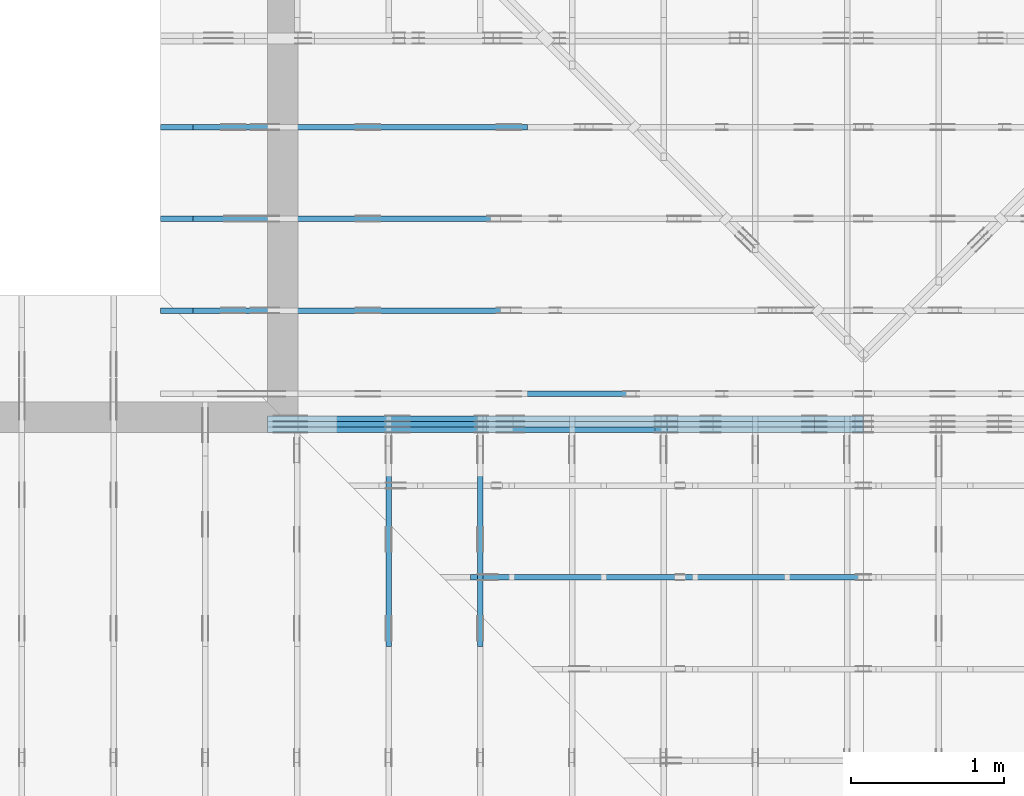
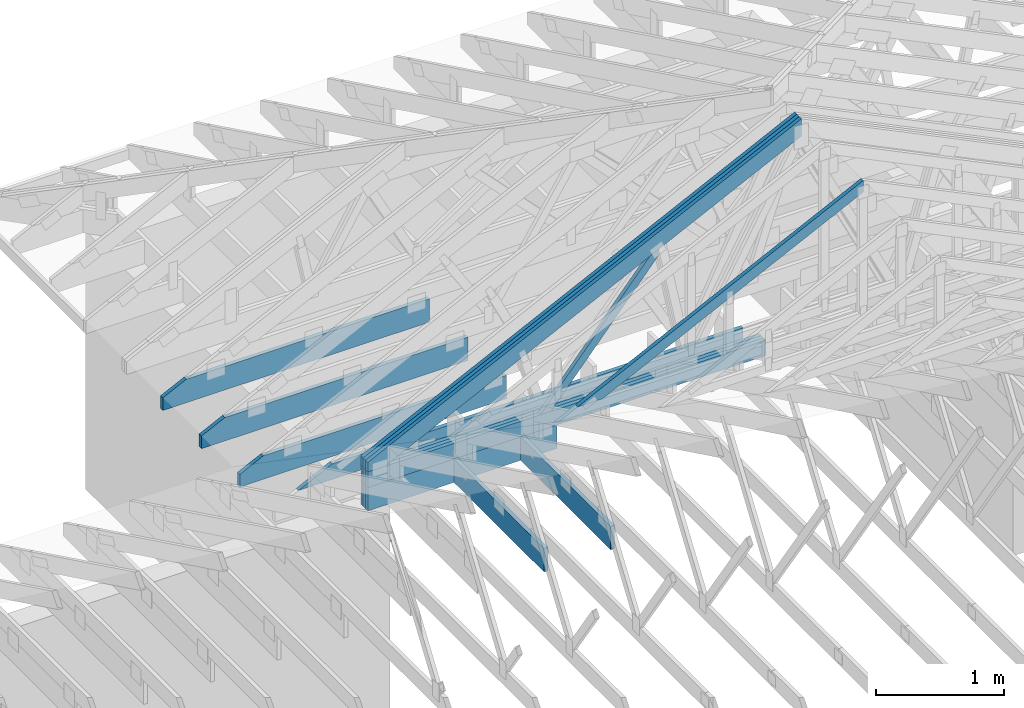
# One storey, part 22 of 159: 17 members, 8 elements without a shape of their own.
"""IFC2X3 building model written with IfcOpenShell, lengths in millimetres."""

from ifc_helpers import new_model, si_unit, frame, origin, origin_with_axes, origin_2d, place, context, project, spatial, faceted_brep, element, aggregate, save


model = new_model("IFC2X3")

# Units and contexts
model_context = context("Model", 3, precision=1e-05, world=origin())
plan_context = context("Plan", 2, precision=1e-05, world=origin_2d())
ifc_project = project(units=[si_unit("LENGTHUNIT", "METRE", prefix="MILLI"), si_unit("AREAUNIT", "SQUARE_METRE"), si_unit("VOLUMEUNIT", "CUBIC_METRE"), si_unit("SOLIDANGLEUNIT", "STERADIAN"), si_unit("PLANEANGLEUNIT", "RADIAN"), si_unit("MASSUNIT", "GRAM"), si_unit("TIMEUNIT", "SECOND"), si_unit("THERMODYNAMICTEMPERATUREUNIT", "DEGREE_CELSIUS"), si_unit("LUMINOUSINTENSITYUNIT", "LUMEN")], contexts=[model_context, plan_context])

# Site, building, storey
site_placement = place(None, origin_with_axes())
site = spatial("IfcSite", under=ifc_project, at=site_placement, CompositionType="ELEMENT")
building_placement = place(site_placement, origin_with_axes())
building = spatial("IfcBuilding", under=site, at=building_placement, Name="Plan 1", CompositionType="ELEMENT")
storey_placement = place(building_placement, origin_with_axes())
storey = spatial("IfcBuildingStorey", under=building, at=storey_placement, Name="Etasje 1", CompositionType="ELEMENT", Elevation=0.0)

# Assembly, members
assembly_1_placement = place(storey_placement, frame((10700.012663101485, 8801.999999990367, 0.0), z_axis=(0.0, -1.0, 6.123031769111886e-17), x_axis=(1.0, 0.0, 0.0)))
assembly_1 = element("IfcElementAssembly", 1, at=assembly_1_placement, inside=storey, Name="T8 (1)", AssemblyPlace="FACTORY", PredefinedType="TRUSS")
member_1_placement = place(assembly_1_placement, frame((29.255809478811415, 311.016701437081, -36.0), z_axis=(0.0, 0.0, 1.0), x_axis=(0.898794046299167, 0.4383711467890774, 0.0)))
member_1 = element("IfcMember", 2, at=member_1_placement, Name="T8-O16", context=model_context, shape_type="Brep", body=[
    faceted_brep([(4378.781899466834, 147.99995674299475, 36.0), (39.634367764929806, 147.99995674299475, 36.0), (0.0, 66.73753437720632, 36.0), (136.8321636846506, 2.8984224002215342e-05, 36.0), (4306.597497456938, 2.8984224002215342e-05, 36.0), (39.634367764929806, 147.99995674299475, 4.853649859466585e-15), (4378.781899466834, 147.99995674299475, 5.362284136089503e-13), (4306.597497456938, 2.8984224002215342e-05, 5.273886658741316e-13), (136.8321636846506, 2.8984224002215342e-05, 1.6756553705548666e-14), (0.0, 66.73753437720632, 0.0), (-1.0658141036401503e-14, 66.73753437720632, 6.040230958362988e-31), (-7.105427357601002e-15, 66.73753437720632, 36.0), (39.634368079159835, 148.00003150847562, 36.0), (39.634368079159835, 148.00003150847562, 7.19847561279507e-31), (136.8321585099013, 3.1508118006229324e-05, 3.565331076937772e-30), (136.8321585099013, 3.1508118006229324e-05, 36.0), (1.0658141036401503e-14, 66.73753437720634, 36.0), (1.0658141036401503e-14, 66.73753437720634, -1.4875703872059745e-30), (4306.5975128248465, 3.150888393548654e-05, -1.4774859213225477e-29), (4306.5975128248465, 3.150888393769083e-05, 36.0), (136.83215850990132, 3.15081180800492e-05, 36.0), (136.83215850990132, 3.150811807784491e-05, -4.694367723059667e-31), (4378.781935933059, 148.0000315098364, 4.4162180043231723e-29), (4378.781935933059, 148.0000315098364, 36.0), (4306.5975128248465, 3.150888392156048e-05, 36.0), (4306.5975128248465, 3.150888392156048e-05, 4.466959351877897e-29), (39.634368079159856, 148.00003150847562, 0.0), (39.634368079159856, 148.00003150847562, 36.0), (4378.781935933059, 148.0000315098358, 36.0), (4378.781935933059, 148.0000315098358, -2.208810534618833e-29)], [[[0, 1, 2, 3, 4]], [[5, 6, 7, 8, 9]], [[10, 11, 12, 13]], [[14, 15, 16, 17]], [[18, 19, 20, 21]], [[22, 23, 24, 25]], [[26, 27, 28, 29]]]),
])
member_2_placement = place(assembly_1_placement, frame((29.255809478811415, 311.016701437081, -72.0), z_axis=(0.0, 0.0, 1.0), x_axis=(0.898794046299167, 0.4383711467890774, 0.0)))
member_2 = element("IfcMember", 3, at=member_2_placement, Name="T8-O16", context=model_context, shape_type="Brep", body=[
    faceted_brep([(4378.781899466834, 147.99995674299475, 36.0), (39.634367764929806, 147.99995674299475, 36.0), (0.0, 66.73753437720632, 36.0), (136.8321636846506, 2.8984224002215342e-05, 36.0), (4306.597497456938, 2.8984224002215342e-05, 36.0), (39.634367764929806, 147.99995674299475, 4.853649859466585e-15), (4378.781899466834, 147.99995674299475, 5.362284136089503e-13), (4306.597497456938, 2.8984224002215342e-05, 5.273886658741316e-13), (136.8321636846506, 2.8984224002215342e-05, 1.6756553705548666e-14), (0.0, 66.73753437720632, 0.0), (-1.0658141036401503e-14, 66.73753437720632, 6.040230958362988e-31), (-7.105427357601002e-15, 66.73753437720632, 36.0), (39.634368079159835, 148.00003150847562, 36.0), (39.634368079159835, 148.00003150847562, 7.19847561279507e-31), (136.8321585099013, 3.1508118006229324e-05, 3.565331076937772e-30), (136.8321585099013, 3.1508118006229324e-05, 36.0), (1.0658141036401503e-14, 66.73753437720634, 36.0), (1.0658141036401503e-14, 66.73753437720634, -1.4875703872059745e-30), (4306.5975128248465, 3.150888393548654e-05, -1.4774859213225477e-29), (4306.5975128248465, 3.150888393769083e-05, 36.0), (136.83215850990132, 3.15081180800492e-05, 36.0), (136.83215850990132, 3.150811807784491e-05, -4.694367723059667e-31), (4378.781935933059, 148.0000315098364, 4.4162180043231723e-29), (4378.781935933059, 148.0000315098364, 36.0), (4306.5975128248465, 3.150888392156048e-05, 36.0), (4306.5975128248465, 3.150888392156048e-05, 4.466959351877897e-29), (39.634368079159856, 148.00003150847562, 0.0), (39.634368079159856, 148.00003150847562, 36.0), (4378.781935933059, 148.0000315098358, 36.0), (4378.781935933059, 148.0000315098358, -2.208810534618833e-29)], [[[0, 1, 2, 3, 4]], [[5, 6, 7, 8, 9]], [[10, 11, 12, 13]], [[14, 15, 16, 17]], [[18, 19, 20, 21]], [[22, 23, 24, 25]], [[26, 27, 28, 29]]]),
])
member_3_placement = place(assembly_1_placement, frame((29.255809478811415, 311.016701437081, -108.0), z_axis=(0.0, 0.0, 1.0), x_axis=(0.898794046299167, 0.4383711467890774, 0.0)))
member_3 = element("IfcMember", 4, at=member_3_placement, Name="T8-O16", context=model_context, shape_type="Brep", body=[
    faceted_brep([(4378.781899466834, 147.99995674299475, 36.0), (39.634367764929806, 147.99995674299475, 36.0), (0.0, 66.73753437720632, 36.0), (136.8321636846506, 2.8984224002215342e-05, 36.0), (4306.597497456938, 2.8984224002215342e-05, 36.0), (39.634367764929806, 147.99995674299475, 4.853649859466585e-15), (4378.781899466834, 147.99995674299475, 5.362284136089503e-13), (4306.597497456938, 2.8984224002215342e-05, 5.273886658741316e-13), (136.8321636846506, 2.8984224002215342e-05, 1.6756553705548666e-14), (0.0, 66.73753437720632, 0.0), (-1.0658141036401503e-14, 66.73753437720632, 6.040230958362988e-31), (-7.105427357601002e-15, 66.73753437720632, 36.0), (39.634368079159835, 148.00003150847562, 36.0), (39.634368079159835, 148.00003150847562, 7.19847561279507e-31), (136.8321585099013, 3.1508118006229324e-05, 3.565331076937772e-30), (136.8321585099013, 3.1508118006229324e-05, 36.0), (1.0658141036401503e-14, 66.73753437720634, 36.0), (1.0658141036401503e-14, 66.73753437720634, -1.4875703872059745e-30), (4306.5975128248465, 3.150888393548654e-05, -1.4774859213225477e-29), (4306.5975128248465, 3.150888393769083e-05, 36.0), (136.83215850990132, 3.15081180800492e-05, 36.0), (136.83215850990132, 3.150811807784491e-05, -4.694367723059667e-31), (4378.781935933059, 148.0000315098364, 4.4162180043231723e-29), (4378.781935933059, 148.0000315098364, 36.0), (4306.5975128248465, 3.150888392156048e-05, 36.0), (4306.5975128248465, 3.150888392156048e-05, 4.466959351877897e-29), (39.634368079159856, 148.00003150847562, 0.0), (39.634368079159856, 148.00003150847562, 36.0), (4378.781935933059, 148.0000315098358, 36.0), (4378.781935933059, 148.0000315098358, -2.208810534618833e-29)], [[[0, 1, 2, 3, 4]], [[5, 6, 7, 8, 9]], [[10, 11, 12, 13]], [[14, 15, 16, 17]], [[18, 19, 20, 21]], [[22, 23, 24, 25]], [[26, 27, 28, 29]]]),
])
member_4_placement = place(assembly_1_placement, frame((3580.0000000000005, 371.0, -36.0), z_axis=(0.0, 0.0, 1.0), x_axis=(-1.0, 1.2246063538223773e-16, 0.0)))
member_4 = element("IfcMember", 5, at=member_4_placement, Name="T8-U40", context=model_context, shape_type="Brep", body=[
    faceted_brep([(3580.0000000000005, 148.00000000000045, 36.0), (4.547473508864641e-13, 148.00000000000045, 36.0), (4.547473508864641e-13, 0.0, 36.0), (3580.0000000000005, 0.0, 36.0), (4.547473508864641e-13, 148.00000000000045, 5.56886495279458e-29), (3580.0000000000005, 148.00000000000045, 4.384090746684111e-13), (3580.0000000000005, 0.0, 4.384090746684111e-13), (4.547473508864641e-13, 0.0, 5.56886495279458e-29), (4.176648714595935e-29, 3.410605131648481e-13, -2.5573752767891235e-45), (2.204291436880321e-15, 3.410605131648481e-13, 36.0), (2.0328465473451507e-14, 148.00000000000037, 36.0), (1.8124174036571228e-14, 148.00000000000037, -1.1097489341483845e-30), (3580.0000000000005, -3.165530988377686e-13, 4.7226971571917616e-29), (3580.0000000000005, -3.143488074008883e-13, 36.0), (4.049083948919771e-31, 3.4326480460172837e-13, 36.0), (0.0, 3.410605131648481e-13, 0.0), (3580.0000000000005, 148.00000000000045, 0.0), (3580.0000000000005, 148.00000000000045, 36.0), (3580.0000000000005, 4.547473508864641e-13, 36.0), (3580.0000000000005, 4.547473508864641e-13, 0.0), (0.0, 148.00000000000037, 0.0), (0.0, 148.00000000000037, 36.0), (3580.0000000000005, 148.00000000000014, 36.0), (3580.0000000000005, 148.00000000000014, -2.0510383535746307e-29)], [[[0, 1, 2, 3]], [[4, 5, 6, 7]], [[8, 9, 10, 11]], [[12, 13, 14, 15]], [[16, 17, 18, 19]], [[20, 21, 22, 23]]]),
])
member_5_placement = place(assembly_1_placement, frame((3580.0000000000005, 371.0, -72.0), z_axis=(0.0, 0.0, 1.0), x_axis=(-1.0, 1.2246063538223773e-16, 0.0)))
member_5 = element("IfcMember", 6, at=member_5_placement, Name="T8-U40", context=model_context, shape_type="Brep", body=[
    faceted_brep([(3580.0000000000005, 148.00000000000045, 36.0), (4.547473508864641e-13, 148.00000000000045, 36.0), (4.547473508864641e-13, 0.0, 36.0), (3580.0000000000005, 0.0, 36.0), (4.547473508864641e-13, 148.00000000000045, 5.56886495279458e-29), (3580.0000000000005, 148.00000000000045, 4.384090746684111e-13), (3580.0000000000005, 0.0, 4.384090746684111e-13), (4.547473508864641e-13, 0.0, 5.56886495279458e-29), (4.176648714595935e-29, 3.410605131648481e-13, -2.5573752767891235e-45), (2.204291436880321e-15, 3.410605131648481e-13, 36.0), (2.0328465473451507e-14, 148.00000000000037, 36.0), (1.8124174036571228e-14, 148.00000000000037, -1.1097489341483845e-30), (3580.0000000000005, -3.165530988377686e-13, 4.7226971571917616e-29), (3580.0000000000005, -3.143488074008883e-13, 36.0), (4.049083948919771e-31, 3.4326480460172837e-13, 36.0), (0.0, 3.410605131648481e-13, 0.0), (3580.0000000000005, 148.00000000000045, 0.0), (3580.0000000000005, 148.00000000000045, 36.0), (3580.0000000000005, 4.547473508864641e-13, 36.0), (3580.0000000000005, 4.547473508864641e-13, 0.0), (0.0, 148.00000000000037, 0.0), (0.0, 148.00000000000037, 36.0), (3580.0000000000005, 148.00000000000014, 36.0), (3580.0000000000005, 148.00000000000014, -2.0510383535746307e-29)], [[[0, 1, 2, 3]], [[4, 5, 6, 7]], [[8, 9, 10, 11]], [[12, 13, 14, 15]], [[16, 17, 18, 19]], [[20, 21, 22, 23]]]),
])
member_6_placement = place(assembly_1_placement, frame((3580.0000000000005, 371.0, -108.0), z_axis=(0.0, 0.0, 1.0), x_axis=(-1.0, 1.2246063538223773e-16, 0.0)))
member_6 = element("IfcMember", 7, at=member_6_placement, Name="T8-U40", context=model_context, shape_type="Brep", body=[
    faceted_brep([(3580.0000000000005, 148.00000000000045, 36.0), (4.547473508864641e-13, 148.00000000000045, 36.0), (4.547473508864641e-13, 0.0, 36.0), (3580.0000000000005, 0.0, 36.0), (4.547473508864641e-13, 148.00000000000045, 5.56886495279458e-29), (3580.0000000000005, 148.00000000000045, 4.384090746684111e-13), (3580.0000000000005, 0.0, 4.384090746684111e-13), (4.547473508864641e-13, 0.0, 5.56886495279458e-29), (4.176648714595935e-29, 3.410605131648481e-13, -2.5573752767891235e-45), (2.204291436880321e-15, 3.410605131648481e-13, 36.0), (2.0328465473451507e-14, 148.00000000000037, 36.0), (1.8124174036571228e-14, 148.00000000000037, -1.1097489341483845e-30), (3580.0000000000005, -3.165530988377686e-13, 4.7226971571917616e-29), (3580.0000000000005, -3.143488074008883e-13, 36.0), (4.049083948919771e-31, 3.4326480460172837e-13, 36.0), (0.0, 3.410605131648481e-13, 0.0), (3580.0000000000005, 148.00000000000045, 0.0), (3580.0000000000005, 148.00000000000045, 36.0), (3580.0000000000005, 4.547473508864641e-13, 36.0), (3580.0000000000005, 4.547473508864641e-13, 0.0), (0.0, 148.00000000000037, 0.0), (0.0, 148.00000000000037, 36.0), (3580.0000000000005, 148.00000000000014, 36.0), (3580.0000000000005, 148.00000000000014, -2.0510383535746307e-29)], [[[0, 1, 2, 3]], [[4, 5, 6, 7]], [[8, 9, 10, 11]], [[12, 13, 14, 15]], [[16, 17, 18, 19]], [[20, 21, 22, 23]]]),
])
member_7_placement = place(assembly_1_placement, frame((-2.0928459567573152e-14, 0.0, -36.0), z_axis=(0.0, 0.0, 1.0), x_axis=(1.0, 0.0, 0.0)))
member_7 = element("IfcMember", 8, at=member_7_placement, Name="T8-KI2", context=model_context, shape_type="Brep", body=[
    faceted_brep([(1700.0, 223.0, 36.0), (1.3638103741762855e-14, 223.0, 36.0), (0.0, 0.0, 36.0), (1700.0, 0.0, 36.0), (1.3638103741762855e-14, 223.0, 1.670130849625153e-30), (1700.0, 223.0, 2.0818308014980413e-13), (1700.0, 0.0, 2.0818308014980413e-13), (0.0, 0.0, 0.0), (6.760513219066083e-22, 0.0, 0.0), (2.204292112931601e-15, -2.6993892992798474e-31, 36.0), (2.9513013803170614e-14, 223.0, 36.0), (2.7308722366290335e-14, 223.0, -8.370563038680858e-31), (1700.0, -3.122746202247062e-13, 1.9120674203232252e-29), (1700.0, -3.100703287878259e-13, 36.0), (6.760513223115168e-22, 2.204291436880279e-15, 36.0), (6.760513219066083e-22, -1.2418451164752748e-37, 7.603857100494559e-54), (1700.0, 223.0, 0.0), (1700.0, 223.0, 36.0), (1700.0, 0.0, 36.0), (1700.0, 0.0, 0.0), (1.3638104028317929e-14, 223.0, 0.0), (1.3638104028317929e-14, 223.0, 36.0), (1700.0, 222.9999999999999, 36.0), (1700.0, 222.9999999999999, -6.310887241768095e-30)], [[[0, 1, 2, 3]], [[4, 5, 6, 7]], [[8, 9, 10, 11]], [[12, 13, 14, 15]], [[16, 17, 18, 19]], [[20, 21, 22, 23]]]),
])
member_8_placement = place(assembly_1_placement, frame((-2.0928459567573152e-14, 0.0, -72.0), z_axis=(0.0, 0.0, 1.0), x_axis=(1.0, 0.0, 0.0)))
member_8 = element("IfcMember", 9, at=member_8_placement, Name="T8-KI2", context=model_context, shape_type="Brep", body=[
    faceted_brep([(1700.0, 223.0, 36.0), (1.3638103741762855e-14, 223.0, 36.0), (0.0, 0.0, 36.0), (1700.0, 0.0, 36.0), (1.3638103741762855e-14, 223.0, 1.670130849625153e-30), (1700.0, 223.0, 2.0818308014980413e-13), (1700.0, 0.0, 2.0818308014980413e-13), (0.0, 0.0, 0.0), (6.760513219066083e-22, 0.0, 0.0), (2.204292112931601e-15, -2.6993892992798474e-31, 36.0), (2.9513013803170614e-14, 223.0, 36.0), (2.7308722366290335e-14, 223.0, -8.370563038680858e-31), (1700.0, -3.122746202247062e-13, 1.9120674203232252e-29), (1700.0, -3.100703287878259e-13, 36.0), (6.760513223115168e-22, 2.204291436880279e-15, 36.0), (6.760513219066083e-22, -1.2418451164752748e-37, 7.603857100494559e-54), (1700.0, 223.0, 0.0), (1700.0, 223.0, 36.0), (1700.0, 0.0, 36.0), (1700.0, 0.0, 0.0), (1.3638104028317929e-14, 223.0, 0.0), (1.3638104028317929e-14, 223.0, 36.0), (1700.0, 222.9999999999999, 36.0), (1700.0, 222.9999999999999, -6.310887241768095e-30)], [[[0, 1, 2, 3]], [[4, 5, 6, 7]], [[8, 9, 10, 11]], [[12, 13, 14, 15]], [[16, 17, 18, 19]], [[20, 21, 22, 23]]]),
])
member_9_placement = place(assembly_1_placement, frame((-2.0928459567573152e-14, 0.0, -108.0), z_axis=(0.0, 0.0, 1.0), x_axis=(1.0, 0.0, 0.0)))
member_9 = element("IfcMember", 10, at=member_9_placement, Name="T8-KI2", context=model_context, shape_type="Brep", body=[
    faceted_brep([(1700.0, 223.0, 36.0), (1.3638103741762855e-14, 223.0, 36.0), (0.0, 0.0, 36.0), (1700.0, 0.0, 36.0), (1.3638103741762855e-14, 223.0, 1.670130849625153e-30), (1700.0, 223.0, 2.0818308014980413e-13), (1700.0, 0.0, 2.0818308014980413e-13), (0.0, 0.0, 0.0), (6.760513219066083e-22, 0.0, 0.0), (2.204292112931601e-15, -2.6993892992798474e-31, 36.0), (2.9513013803170614e-14, 223.0, 36.0), (2.7308722366290335e-14, 223.0, -8.370563038680858e-31), (1700.0, -3.122746202247062e-13, 1.9120674203232252e-29), (1700.0, -3.100703287878259e-13, 36.0), (6.760513223115168e-22, 2.204291436880279e-15, 36.0), (6.760513219066083e-22, -1.2418451164752748e-37, 7.603857100494559e-54), (1700.0, 223.0, 0.0), (1700.0, 223.0, 36.0), (1700.0, 0.0, 36.0), (1700.0, 0.0, 0.0), (1.3638104028317929e-14, 223.0, 0.0), (1.3638104028317929e-14, 223.0, 36.0), (1700.0, 222.9999999999999, 36.0), (1700.0, 222.9999999999999, -6.310887241768095e-30)], [[[0, 1, 2, 3]], [[4, 5, 6, 7]], [[8, 9, 10, 11]], [[12, 13, 14, 15]], [[16, 17, 18, 19]], [[20, 21, 22, 23]]]),
])
member_10_placement = place(assembly_1_placement, frame((2588.98150183582, 1596.6429683989554, -36.0), z_axis=(0.0, 0.0, 1.0), x_axis=(-0.6458357364032298, -0.7634763922902252, 0.0)))
member_10 = element("IfcMember", 11, at=member_10_placement, Name="T8-D24", context=model_context, shape_type="Brep", body=[
    faceted_brep([(1543.5932006244534, 72.99998709430429, 36.0), (28.88351769405017, 72.99998709430429, 36.0), (1.4494809875031933e-05, 36.500010319543776, 36.0), (82.86761682691758, 1.7008971553877927e-05, 36.0), (1605.3449359283989, 1.7008971553877927e-05, 36.0), (28.88351769405017, 72.99998709430429, 3.5370939288874897e-15), (1543.5932006244534, 72.99998709430429, 1.890294041201725e-13), (1605.3449359283989, 1.7008971553877927e-05, 1.9659156086144943e-13), (82.86761682691758, 1.7008971553877927e-05, 1.0148021009236142e-14), (1.4494809875031933e-05, 36.500010319543776, 1.7750436270411443e-21), (-3.552713678800501e-15, 36.499999999876884, 3.944304526105059e-31), (-3.552713678800501e-15, 36.499999999876884, 36.0), (28.883460935114723, 73.00000000000034, 36.0), (28.883460935114723, 73.00000000000034, 3.944304526105059e-31), (82.8676636786472, -3.552713678800501e-15, 0.0), (82.8676636786472, 0.0, 36.0), (1.7763568394002505e-15, 36.49999999987688, 36.0), (0.0, 36.49999999987688, 0.0), (1605.3449468455124, -3.4439067704007967e-13, 7.67758000929694e-29), (1605.3449468455124, -3.421863856031994e-13, 36.0), (82.8676636786472, -6.252108242574337e-14, 36.0), (82.8676636786472, -6.472537386262365e-14, 3.963155204284888e-30), (1543.5931897073374, 73.00000000000114, 1.262177448353619e-29), (1543.5931897073374, 73.00000000000114, 36.0), (1605.3449468455124, 9.094947017729282e-13, 36.0), (1605.3449468455124, 9.094947017729282e-13, 0.0), (28.883460935114726, 73.00000000000036, 7.888609052210118e-31), (28.883460935114726, 73.00000000000036, 36.0), (1543.5931897073374, 73.0000000000016, 36.0), (1543.5931897073374, 73.0000000000016, 2.8398992587956425e-29)], [[[0, 1, 2, 3, 4]], [[5, 6, 7, 8, 9]], [[10, 11, 12, 13]], [[14, 15, 16, 17]], [[18, 19, 20, 21]], [[22, 23, 24, 25]], [[26, 27, 28, 29]]]),
])
aggregate(assembly_1, [member_1, member_2, member_3, member_4, member_5, member_6, member_7, member_8, member_9, member_10])

# Assembly, member
assembly_2_placement = place(storey_placement, frame((19200.01266310149, 9617.999978540158, 1.1021457184401395e-15), z_axis=(1.2246063538223773e-16, 1.0, 6.123031769111886e-17), x_axis=(-1.0, 1.2246063538223773e-16, 0.0)))
assembly_2 = element("IfcElementAssembly", 12, at=assembly_2_placement, inside=storey, Name="V12 (104)", AssemblyPlace="FACTORY", PredefinedType="TRUSS")
member_11_placement = place(assembly_2_placement, frame((6799.999999999984, 0.0, -36.0), z_axis=(0.0, 0.0, 1.0), x_axis=(1.0, 0.0, 0.0)))
member_11 = element("IfcMember", 13, at=member_11_placement, Name="V12-U13", context=model_context, shape_type="Brep", body=[
    faceted_brep([(2188.8183593750164, 223.0, 36.0), (1.6370904631912708e-11, 223.0, 36.0), (1.6370904631912708e-11, 0.0, 36.0), (2400.0000000000164, 0.0, 36.0), (2400.0000000000164, 120.0, 36.0), (1.6370904631912708e-11, 223.0, 2.004791383006049e-27), (2188.8183593750164, 223.0, 2.6804408702537167e-13), (2400.0000000000164, 120.0, 2.9390552491737256e-13), (2400.0000000000164, 0.0, 2.9390552491737256e-13), (1.6370904631912708e-11, 0.0, 2.004791383006049e-27), (2.3646862246096134e-11, 223.0, 0.0), (2.3646862246096134e-11, 223.0, 36.0), (2188.818704316409, 222.99999999999986, 36.0), (2188.818704316409, 222.99999999999986, -7.888609052210118e-30), (0.0, 0.0, 0.0), (2.204291436880279e-15, -2.342275270834659e-28, 36.0), (2.3698135630505907e-11, 223.0, 36.0), (2.3695931339069026e-11, 223.0, -3.0045161515452303e-30), (2400.0, -4.408582873760558e-13, 2.6993892992798474e-29), (2400.0, -4.3865399593917553e-13, 36.0), (4.049083948919771e-31, 2.204291436880279e-15, 36.0), (0.0, 0.0, 0.0), (2400.0, 119.99999999974528, -1.4388822911231255e-27), (2400.0, 119.99999999974528, 36.0), (2400.0, 0.0, 36.0), (2400.0, 0.0, 0.0), (2188.818704316409, 223.0000000000001, 5.760966308578438e-30), (2188.818704316409, 223.0000000000001, 36.0), (2400.0000000000236, 119.99999999974534, 36.0), (2400.0000000000236, 119.99999999974534, 6.484994924880212e-30)], [[[0, 1, 2, 3, 4]], [[5, 6, 7, 8, 9]], [[10, 11, 12, 13]], [[14, 15, 16, 17]], [[18, 19, 20, 21]], [[22, 23, 24, 25]], [[26, 27, 28, 29]]]),
])
aggregate(assembly_2, [member_11])

assembly_3_placement = place(storey_placement, frame((10000.012663278096, 9072.000080051337, 1.1021457184401395e-15), z_axis=(9.811600543477555e-09, 1.0, 6.123031769111886e-17), x_axis=(-1.0, 9.811600543477555e-09, 0.0)))
assembly_3 = element("IfcElementAssembly", 14, at=assembly_3_placement, inside=storey, Name="T9 (79)", AssemblyPlace="FACTORY", PredefinedType="TRUSS")
member_12_placement = place(assembly_3_placement, frame((-211.18128967285153, 371.0, -36.0), z_axis=(0.0, 0.0, 1.0), x_axis=(-1.0, 1.2246063538223773e-16, 0.0)))
member_12 = element("IfcMember", 15, at=member_12_placement, Name="T9-U38", context=model_context, shape_type="Brep", body=[
    faceted_brep([(3997.6375579833984, 148.0000000000005, 36.0), (0.0, 148.0000000000005, 36.0), (303.4449920654297, 5.684341886080802e-14, 36.0), (3997.6375579833984, 5.684341886080802e-14, 36.0), (0.0, 148.0000000000005, 0.0), (3997.6375579833984, 148.0000000000005, 4.895532353785442e-13), (3997.6375579833984, 5.684341886080802e-14, 4.895532353785442e-13), (303.4449920654297, 5.684341886080802e-14, 3.7160066531890605e-14), (303.44497456401587, -4.263256414560601e-14, 4.733165431326071e-30), (303.44497456401587, -4.263256414560601e-14, 36.0), (6.010755896568298e-06, 147.9999999990687, 36.0), (6.010755896568298e-06, 147.9999999990687, -1.5777218104420236e-30), (3997.637414643541, -6.728172277866374e-13, 4.119681260543369e-29), (3997.637414643541, -6.706129363497571e-13, 36.0), (303.44497456401587, 7.97679380483959e-15, 36.0), (303.44497456401587, 5.772502367959311e-15, 3.127088441633728e-30), (3997.637414643541, 148.0, 0.0), (3997.637414643541, 148.0, 36.0), (3997.637414643541, 0.0, 36.0), (3997.637414643541, 0.0, 0.0), (6.010755896568298e-06, 147.9999999990687, 0.0), (6.010755896568298e-06, 147.9999999990687, 36.0), (3997.637414643541, 147.9999999999996, 36.0), (3997.637414643541, 147.9999999999996, -2.3665827156630354e-29)], [[[0, 1, 2, 3]], [[4, 5, 6, 7]], [[8, 9, 10, 11]], [[12, 13, 14, 15]], [[16, 17, 18, 19]], [[20, 21, 22, 23]]]),
])
aggregate(assembly_3, [member_12])

assembly_4_placement = place(storey_placement, frame((12075.022261404752, -699.9989301294854, 4.558494966049043e-13), z_axis=(-1.0, 1.836909530733566e-16, 6.123031769111886e-17), x_axis=(-1.836909530733566e-16, -1.0, 0.0)))
assembly_4 = element("IfcElementAssembly", 16, at=assembly_4_placement, inside=storey, Name="T5 (98)", AssemblyPlace="FACTORY", PredefinedType="TRUSS")
member_13_placement = place(assembly_4_placement, frame((-9501.9990234375, 0.0, -36.0), z_axis=(0.0, 0.0, 1.0), x_axis=(1.0, 0.0, 0.0)))
member_13 = element("IfcMember", 17, at=member_13_placement, Name="T5-U19", context=model_context, shape_type="Brep", body=[
    faceted_brep([(1402.0, 223.0, 36.0), (0.0, 223.0, 36.0), (0.0, 0.0, 36.0), (1402.0, 0.0, 36.0), (0.0, 223.0, 0.0), (1402.0, 223.0, 1.716898108058973e-13), (1402.0, 0.0, 1.716898108058973e-13), (0.0, 0.0, 0.0), (9.331764886155725e-05, 0.0, 0.0), (9.331764886376154e-05, -2.6993892992798474e-31, 36.0), (9.331764889107026e-05, 223.0, 36.0), (9.331764888886597e-05, 223.0, -1.6721217180559947e-30), (1402.0000933176434, -2.5753473335045277e-13, 1.5768933539545808e-29), (1402.0000933176434, -2.553304419135725e-13, 36.0), (9.331764886155725e-05, 2.204274295272421e-15, 36.0), (9.331764886155725e-05, -1.714160785794428e-20, 1.0495860948785078e-36), (1402.0000933176434, 223.0, 0.0), (1402.0000933176434, 223.0, 36.0), (1402.0000933176434, 0.0, 36.0), (1402.0000933176434, 0.0, 0.0), (9.331764886155725e-05, 223.0, 0.0), (9.331764886155725e-05, 223.0, 36.0), (1402.0000933176434, 222.99999999999991, 36.0), (1402.0000933176434, 222.99999999999991, -4.733165431326071e-30)], [[[0, 1, 2, 3]], [[4, 5, 6, 7]], [[8, 9, 10, 11]], [[12, 13, 14, 15]], [[16, 17, 18, 19]], [[20, 21, 22, 23]]]),
])
aggregate(assembly_4, [member_13])

assembly_5_placement = place(storey_placement, frame((11475.022261404752, -699.9989301294845, 1.1021457184401395e-15), z_axis=(-1.0, 1.836909530733566e-16, 6.123031769111886e-17), x_axis=(-1.836909530733566e-16, -1.0, 0.0)))
assembly_5 = element("IfcElementAssembly", 18, at=assembly_5_placement, inside=storey, Name="T5 (97)", AssemblyPlace="FACTORY", PredefinedType="TRUSS")
member_14_placement = place(assembly_5_placement, frame((-9501.9990234375, 0.0, -36.0), z_axis=(0.0, 0.0, 1.0), x_axis=(1.0, 0.0, 0.0)))
member_14 = element("IfcMember", 19, at=member_14_placement, Name="T5-U19", context=model_context, shape_type="Brep", body=[
    faceted_brep([(1402.0, 223.0, 36.0), (0.0, 223.0, 36.0), (0.0, 0.0, 36.0), (1402.0, 0.0, 36.0), (0.0, 223.0, 0.0), (1402.0, 223.0, 1.716898108058973e-13), (1402.0, 0.0, 1.716898108058973e-13), (0.0, 0.0, 0.0), (9.331764886155725e-05, 0.0, 0.0), (9.331764886376154e-05, -2.6993892992798474e-31, 36.0), (9.331764889107026e-05, 223.0, 36.0), (9.331764888886597e-05, 223.0, -1.6721217180559947e-30), (1402.0000933176434, -2.5753473335045277e-13, 1.5768933539545808e-29), (1402.0000933176434, -2.553304419135725e-13, 36.0), (9.331764886155725e-05, 2.204274295272421e-15, 36.0), (9.331764886155725e-05, -1.714160785794428e-20, 1.0495860948785078e-36), (1402.0000933176434, 223.0, 0.0), (1402.0000933176434, 223.0, 36.0), (1402.0000933176434, 0.0, 36.0), (1402.0000933176434, 0.0, 0.0), (9.331764886155725e-05, 223.0, 0.0), (9.331764886155725e-05, 223.0, 36.0), (1402.0000933176434, 222.99999999999991, 36.0), (1402.0000933176434, 222.99999999999991, -4.733165431326071e-30)], [[[0, 1, 2, 3]], [[4, 5, 6, 7]], [[8, 9, 10, 11]], [[12, 13, 14, 15]], [[16, 17, 18, 19]], [[20, 21, 22, 23]]]),
])
aggregate(assembly_5, [member_14])

assembly_6_placement = place(storey_placement, frame((19200.01266310149, 10817.999978540158, 1.1021457184401395e-15), z_axis=(1.2246063538223773e-16, 1.0, 6.123031769111886e-17), x_axis=(-1.0, 1.2246063538223773e-16, 0.0)))
assembly_6 = element("IfcElementAssembly", 20, at=assembly_6_placement, inside=storey, Name="V10 (59)", AssemblyPlace="FACTORY", PredefinedType="TRUSS")
member_15_placement = place(assembly_6_placement, frame((6799.999999999976, 7.237830359838992e-25, -36.0), z_axis=(0.0, 0.0, 1.0), x_axis=(1.0, -1.0593815321507938e-13, 0.0)))
member_15 = element("IfcMember", 21, at=member_15_placement, Name="V10-U13", context=model_context, shape_type="Brep", body=[
    faceted_brep([(2188.818359375, 223.0000000002319, 36.0), (0.0, 223.0000000002319, 36.0), (2.3646862246096134e-11, 1.7577588016751838e-24, 36.0), (2400.0000000000236, 1.7577588016751838e-24, 36.0), (2400.000000000011, 120.00000000025426, 36.0), (0.0, 223.0, 0.0), (2188.818359375, 223.0, 2.6804408702536966e-13), (2400.000000000011, 120.00000000025426, 2.9390552491737185e-13), (2400.0000000000236, 1.7577588016751838e-24, 2.939055249173734e-13), (2.3646862246096134e-11, 1.7577588016751838e-24, 2.8958097754531817e-27), (7.275957614183426e-12, 223.0, 0.0), (7.275957614183426e-12, 223.0, 36.0), (2188.8187043163925, 223.0000000002317, 36.0), (2188.8187043163925, 223.0000000002317, -1.262177448353619e-29), (7.275957614183426e-12, 0.0, 0.0), (7.278161905620306e-12, -2.6993892992798474e-31, 36.0), (7.305470627310545e-12, 223.0, 36.0), (7.303266335873665e-12, 223.0, -1.6721217048316832e-30), (2400.0000000000073, 2.5535452658626e-10, -6.753452201458905e-29), (2400.0000000000073, 2.553567308776969e-10, 36.0), (7.275957614183426e-12, 2.204291436883623e-15, 36.0), (7.275957614183426e-12, 3.343784162005288e-27, -2.0474096653011194e-43), (2400.0000000000073, 119.9999999999996, -6.563322731438818e-28), (2400.0000000000073, 119.9999999999996, 36.0), (2400.0000000000073, 2.542515677161906e-10, 36.0), (2400.0000000000073, 2.542515677161906e-10, 0.0), (2188.8187043163925, 223.0000000002318, -6.86080817495773e-30), (2188.8187043163925, 223.0000000002318, 36.0), (2400.000000000018, 119.99999999999943, 36.0), (2400.000000000018, 119.99999999999943, -6.136779558655956e-30)], [[[0, 1, 2, 3, 4]], [[5, 6, 7, 8, 9]], [[10, 11, 12, 13]], [[14, 15, 16, 17]], [[18, 19, 20, 21]], [[22, 23, 24, 25]], [[26, 27, 28, 29]]]),
])
aggregate(assembly_6, [member_15])

assembly_7_placement = place(storey_placement, frame((19200.01266310149, 10217.999978540158, 1.1021457184401395e-15), z_axis=(1.2246063538223773e-16, 1.0, 6.123031769111886e-17), x_axis=(-1.0, 1.2246063538223773e-16, 0.0)))
assembly_7 = element("IfcElementAssembly", 22, at=assembly_7_placement, inside=storey, Name="V11 (60)", AssemblyPlace="FACTORY", PredefinedType="TRUSS")
member_16_placement = place(assembly_7_placement, frame((6800.0, 0.0, -36.0), z_axis=(0.0, 0.0, 1.0), x_axis=(1.0, 0.0, 0.0)))
member_16 = element("IfcMember", 23, at=member_16_placement, Name="V11-U13", context=model_context, shape_type="Brep", body=[
    faceted_brep([(2188.818359375, 223.0, 36.0), (0.0, 223.0, 36.0), (0.0, 0.0, 36.0), (2400.0, 0.0, 36.0), (2400.0, 120.0, 36.0), (0.0, 223.0, 0.0), (2188.818359375, 223.0, 2.6804408702536966e-13), (2400.0, 120.0, 2.9390552491737054e-13), (2400.0, 0.0, 2.9390552491737054e-13), (0.0, 0.0, 0.0), (7.275957614183426e-12, 223.0, 0.0), (7.275957614183426e-12, 223.0, 36.0), (2188.8187043163925, 222.99999999999986, 36.0), (2188.8187043163925, 222.99999999999986, -7.888609052210118e-30), (7.275957614183426e-12, 0.0, 0.0), (7.278161905620306e-12, -2.6993892992798474e-31, 36.0), (7.305470627310545e-12, 223.0, 36.0), (7.303266335873665e-12, 223.0, -1.6721217048316832e-30), (2400.0000000000073, -4.4085828737605713e-13, 2.699389299279856e-29), (2400.0000000000073, -4.3865399593917685e-13, 36.0), (7.275957614183426e-12, 2.2042914368789427e-15, 36.0), (7.275957614183426e-12, -1.3365275886706993e-27, 8.183600885725195e-44), (2400.0000000000073, 119.9999999997452, 0.0), (2400.0000000000073, 119.9999999997452, 36.0), (2400.0000000000073, 0.0, 36.0), (2400.0000000000073, 0.0, 0.0), (2188.8187043163925, 222.99999999999977, -1.262177448353619e-29), (2188.8187043163925, 222.99999999999977, 36.0), (2400.0000000000073, 119.999999999745, 36.0), (2400.0000000000073, 119.999999999745, -2.524354896707238e-29)], [[[0, 1, 2, 3, 4]], [[5, 6, 7, 8, 9]], [[10, 11, 12, 13]], [[14, 15, 16, 17]], [[18, 19, 20, 21]], [[22, 23, 24, 25]], [[26, 27, 28, 29]]]),
])
aggregate(assembly_7, [member_16])

assembly_8_placement = place(storey_placement, frame((11846.012601162385, 7836.000061939094, 1020.3543282828622), z_axis=(0.0, -1.0, 6.123031769111886e-17), x_axis=(1.0, 0.0, 0.0)))
assembly_8 = element("IfcElementAssembly", 24, at=assembly_8_placement, inside=storey, Name="Tr2 (1)", AssemblyPlace="FACTORY", PredefinedType="TRUSS")
member_17_placement = place(assembly_8_placement, frame((225.89018749427674, 1.1389989600166786, -36.0), z_axis=(0.0, 0.0, 1.0), x_axis=(0.898794046299167, 0.4383711467890774, 0.0)))
member_17 = element("IfcMember", 25, at=member_17_placement, Name="Tr2-O82", context=model_context, shape_type="Brep", body=[
    faceted_brep([(2860.5776961017696, 98.00003955872921, 36.0), (2.6177280858519225e-06, 98.00003955872921, 36.0), (200.92978933910402, 1.3004113270653761e-05, 36.0), (2812.779883128234, 1.3004113270653761e-05, 36.0), (2.6177280858519225e-06, 98.00003955872921, 3.205686446513554e-22), (2860.5776961017696, 98.00003955872921, 3.5030816222488045e-13), (2812.779883128234, 1.3004113270653761e-05, 3.444548116782599e-13), (200.92978933910402, 1.3004113270653761e-05, 2.4605989669685853e-14), (200.92977647567358, 1.5056076165365084e-05, 3.7119433284801e-30), (200.92977647567358, 1.5056076165365084e-05, 36.0), (0.0, 98.00001505651646, 36.0), (0.0, 98.00001505651646, -1.323818884971677e-31), (2812.7799593858945, 1.5057636974828858e-05, -2.4539435186014577e-29), (2812.7799593858945, 1.505763697703315e-05, 36.0), (200.9297764756736, 1.5056076238830967e-05, 36.0), (200.9297764756736, 1.5056076236626676e-05, -1.7529645082626102e-30), (2860.577753064828, 98.00001505657087, -7.573064690121713e-29), (2860.577753064828, 98.00001505657087, 36.0), (2812.7799593858936, 1.5057636801429908e-05, 36.0), (2812.7799593858936, 1.5057636801429908e-05, -5.048709793414476e-29), (0.0, 98.00001505651645, 0.0), (0.0, 98.00001505651645, 36.0), (2860.577753064829, 98.00001505657089, 36.0), (2860.577753064829, 98.0000150565709, 1.4988357199199224e-29)], [[[0, 1, 2, 3]], [[4, 5, 6, 7]], [[8, 9, 10, 11]], [[12, 13, 14, 15]], [[16, 17, 18, 19]], [[20, 21, 22, 23]]]),
])
aggregate(assembly_8, [member_17])

save(model, "model.ifc")
